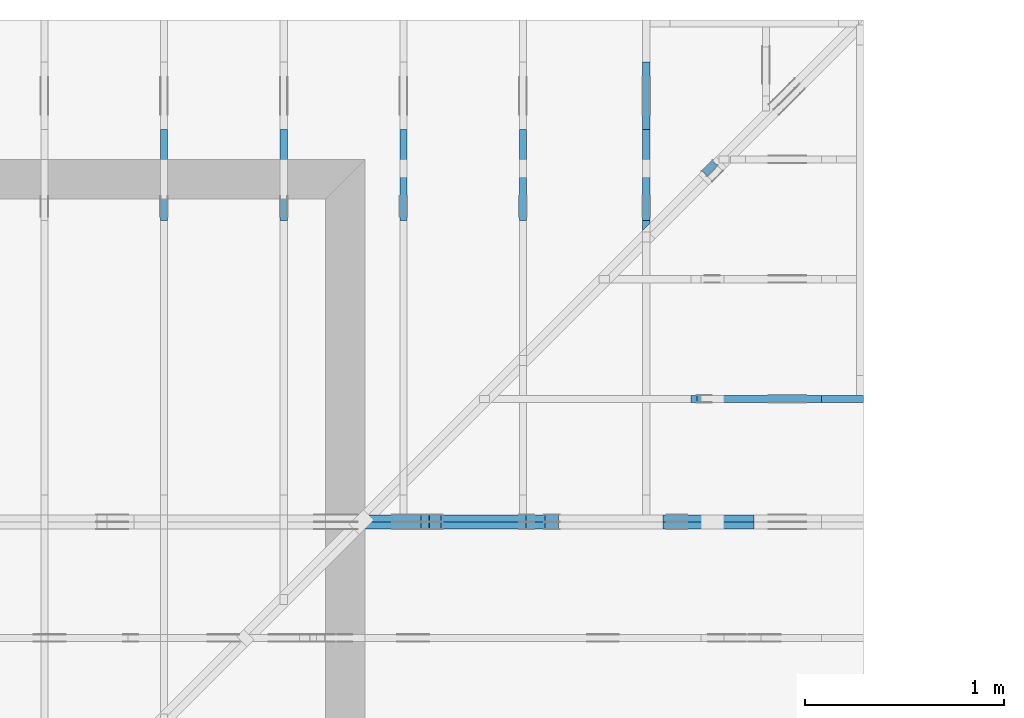
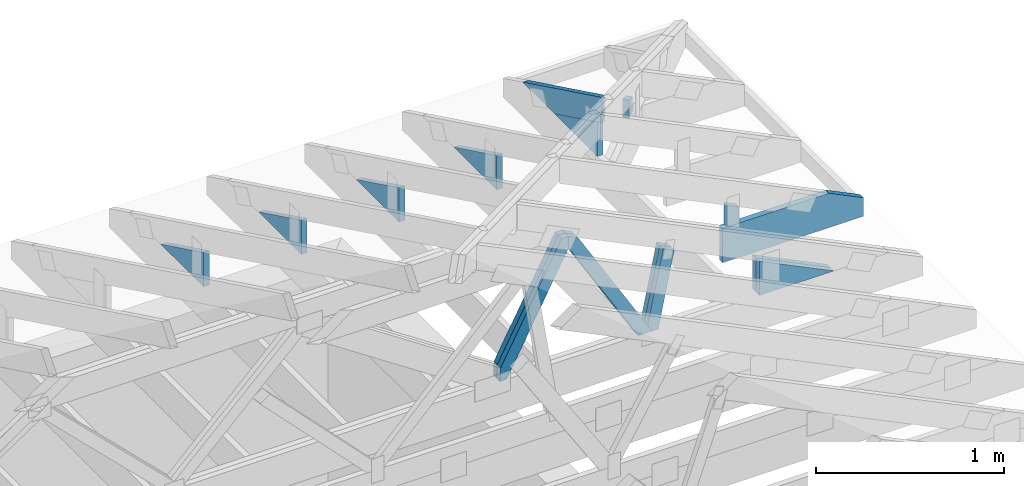
# One storey, part 52 of 159: 17 members, 8 elements without a shape of their own.
"""IFC2X3 building model written with IfcOpenShell, lengths in millimetres."""

from ifc_helpers import new_model, si_unit, frame, origin, origin_with_axes, origin_2d, place, context, project, spatial, faceted_brep, element, aggregate, save


model = new_model("IFC2X3")

# Units and contexts
model_context = context("Model", 3, precision=1e-05, world=origin())
plan_context = context("Plan", 2, precision=1e-05, world=origin_2d())
ifc_project = project(units=[si_unit("LENGTHUNIT", "METRE", prefix="MILLI"), si_unit("AREAUNIT", "SQUARE_METRE"), si_unit("VOLUMEUNIT", "CUBIC_METRE"), si_unit("SOLIDANGLEUNIT", "STERADIAN"), si_unit("PLANEANGLEUNIT", "RADIAN"), si_unit("MASSUNIT", "GRAM"), si_unit("TIMEUNIT", "SECOND"), si_unit("THERMODYNAMICTEMPERATUREUNIT", "DEGREE_CELSIUS"), si_unit("LUMINOUSINTENSITYUNIT", "LUMEN")], contexts=[model_context, plan_context])

# Site, building, storey
site_placement = place(None, origin_with_axes())
site = spatial("IfcSite", under=ifc_project, at=site_placement, CompositionType="ELEMENT")
building_placement = place(site_placement, origin_with_axes())
building = spatial("IfcBuilding", under=site, at=building_placement, Name="Plan 1", CompositionType="ELEMENT")
storey_placement = place(building_placement, origin_with_axes())
storey = spatial("IfcBuildingStorey", under=building, at=storey_placement, Name="Etasje 1", CompositionType="ELEMENT", Elevation=0.0)

# Assembly, members
assembly_1_placement = place(storey_placement, frame((19200.01266310149, 11417.999978540158, 0.0), z_axis=(1.2246063538223773e-16, 1.0, 6.123031769111886e-17), x_axis=(-1.0, 1.2246063538223773e-16, 0.0)))
assembly_1 = element("IfcElementAssembly", 1, at=assembly_1_placement, inside=storey, Name="V9 (1)", AssemblyPlace="FACTORY", PredefinedType="TRUSS")
member_1_placement = place(assembly_1_placement, frame((2147.17242569725, 1036.525654705254, -36.0), z_axis=(0.0, 0.0, 1.0), x_axis=(-0.5106442206411709, -0.8597921143658921, 0.0)))
member_1 = element("IfcMember", 2, at=member_1_placement, Name="V9-D52", context=model_context, shape_type="Brep", body=[
    faceted_brep([(902.8328949356044, 73.00004492890571, 36.0), (65.0651518296686, 73.00004492890571, 36.0), (0.0, 36.500109060107434, 36.0), (55.580187036672214, 5.475690727507754e-05, 36.0), (946.1887834424253, 5.475690727507754e-05, 36.0), (65.0651518296686, 73.00004492890571, 7.967919834302984e-15), (902.8328949356044, 73.00004492890571, 1.1056148995779919e-13), (946.1887834424253, 5.475690727507754e-05, 1.1587087961190594e-13), (55.580187036672214, 5.475690727507754e-05, 6.806385019174492e-15), (0.0, 36.500109060107434, 0.0), (2.7086670565168447e-05, 36.500022463280175, 3.944304526105059e-31), (2.7086670566944804e-05, 36.500022463280175, 36.0), (65.06518656391151, 73.00002246445024, 36.0), (65.06518656391151, 73.00002246445024, 1.1832913578315177e-30), (55.58023588162587, 2.2464449568104783e-05, 0.0), (55.58023588162587, 2.2464449571657497e-05, 36.0), (2.7086670566944804e-05, 36.500022463280175, 36.0), (2.7086670566944804e-05, 36.500022463280175, 3.944304526105059e-31), (946.18877010043, 2.2464450950891487e-05, 2.6056228585185683e-29), (946.18877010043, 2.246445095309578e-05, 36.0), (55.58023588162587, 2.2464449534653947e-05, 36.0), (55.58023588162587, 2.2464449532449656e-05, 1.5305735783864743e-30), (902.8329082776017, 73.00002246445126, 2.015989991758447e-29), (902.8329082776017, 73.00002246445126, 36.0), (946.1887701004302, 2.2464451490122883e-05, 36.0), (946.1887701004302, 2.2464451490122883e-05, 2.0421531320973567e-29), (65.06518656391152, 73.00002246445024, -7.888609052210118e-31), (65.06518656391152, 73.00002246445024, 36.0), (902.8329082776015, 73.0000224644511, 36.0), (902.8329082776015, 73.00002246445112, -1.5777218104420236e-30)], [[[0, 1, 2, 3, 4]], [[5, 6, 7, 8, 9]], [[10, 11, 12, 13]], [[14, 15, 16, 17]], [[18, 19, 20, 21]], [[22, 23, 24, 25]], [[26, 27, 28, 29]]]),
])
member_2_placement = place(assembly_1_placement, frame((2147.17242569725, 1036.525654705254, -72.0), z_axis=(0.0, 0.0, 1.0), x_axis=(-0.5106442206411709, -0.8597921143658921, 0.0)))
member_2 = element("IfcMember", 3, at=member_2_placement, Name="V9-D52", context=model_context, shape_type="Brep", body=[
    faceted_brep([(902.8328949356044, 73.00004492890571, 36.0), (65.0651518296686, 73.00004492890571, 36.0), (0.0, 36.500109060107434, 36.0), (55.580187036672214, 5.475690727507754e-05, 36.0), (946.1887834424253, 5.475690727507754e-05, 36.0), (65.0651518296686, 73.00004492890571, 7.967919834302984e-15), (902.8328949356044, 73.00004492890571, 1.1056148995779919e-13), (946.1887834424253, 5.475690727507754e-05, 1.1587087961190594e-13), (55.580187036672214, 5.475690727507754e-05, 6.806385019174492e-15), (0.0, 36.500109060107434, 0.0), (2.7086670565168447e-05, 36.500022463280175, 3.944304526105059e-31), (2.7086670566944804e-05, 36.500022463280175, 36.0), (65.06518656391151, 73.00002246445024, 36.0), (65.06518656391151, 73.00002246445024, 1.1832913578315177e-30), (55.58023588162587, 2.2464449568104783e-05, 0.0), (55.58023588162587, 2.2464449571657497e-05, 36.0), (2.7086670566944804e-05, 36.500022463280175, 36.0), (2.7086670566944804e-05, 36.500022463280175, 3.944304526105059e-31), (946.18877010043, 2.2464450950891487e-05, 2.6056228585185683e-29), (946.18877010043, 2.246445095309578e-05, 36.0), (55.58023588162587, 2.2464449534653947e-05, 36.0), (55.58023588162587, 2.2464449532449656e-05, 1.5305735783864743e-30), (902.8329082776017, 73.00002246445126, 2.015989991758447e-29), (902.8329082776017, 73.00002246445126, 36.0), (946.1887701004302, 2.2464451490122883e-05, 36.0), (946.1887701004302, 2.2464451490122883e-05, 2.0421531320973567e-29), (65.06518656391152, 73.00002246445024, -7.888609052210118e-31), (65.06518656391152, 73.00002246445024, 36.0), (902.8329082776015, 73.0000224644511, 36.0), (902.8329082776015, 73.00002246445112, -1.5777218104420236e-30)], [[[0, 1, 2, 3, 4]], [[5, 6, 7, 8, 9]], [[10, 11, 12, 13]], [[14, 15, 16, 17]], [[18, 19, 20, 21]], [[22, 23, 24, 25]], [[26, 27, 28, 29]]]),
])
member_3_placement = place(assembly_1_placement, frame((2146.290166525298, 1000.8211263302463, -36.0), z_axis=(0.0, 0.0, 1.0), x_axis=(0.4675598504153547, -0.8839614167369361, 0.0)))
member_3 = element("IfcMember", 4, at=member_3_placement, Name="V9-D55", context=model_context, shape_type="Brep", body=[
    faceted_brep([(821.1597178334184, 73.00008756388706, 36.0), (19.30619502132629, 73.00008756388706, 36.0), (5.9781849017781497e-05, 36.50016454658953, 36.0), (65.06517371963639, 0.00014569213362847222, 36.0), (879.9265574299643, 0.00014569213362847222, 36.0), (899.2328068197955, 36.50016454658953, 36.0), (19.30619502132629, 73.00008756388706, 2.364248909125012e-15), (821.1597178334184, 73.00008756388706, 1.0055974079617946e-13), (899.2328068197955, 36.50016454658953, 1.101206208797052e-13), (879.9265574299643, 0.00014569213362847222, 1.0775636531257853e-13), (65.06517371963639, 0.00014569213362847222, 7.967922514962348e-15), (5.9781849017781497e-05, 36.50016454658953, 7.320923215042526e-21), (-3.552713678800501e-15, 36.500096290976686, 2.950072410108183e-31), (-1.7763568394002505e-15, 36.500096290976686, 36.0), (19.306198457980017, 73.0000962921745, 36.0), (19.306198457980017, 73.0000962921745, 1.1538444380923034e-30), (65.06515947856828, 9.629217493056785e-05, -3.944304526105059e-31), (65.06515947856828, 9.629217493412057e-05, 36.0), (0.0, 36.50009629097667, 36.0), (-1.7763568394002505e-15, 36.50009629097667, 0.0), (879.9266083624536, 9.629217547784367e-05, 2.2178777526116974e-29), (879.9266083624536, 9.629217548004797e-05, 36.0), (65.06515947856826, 9.629217490598829e-05, 36.0), (65.06515947856826, 9.6292174903784e-05, 1.6399842667418017e-30), (899.2328068198412, 36.5000962921564, -1.8932661725304283e-29), (899.2328068198412, 36.5000962921564, 36.0), (879.9266083624534, 9.629217595374939e-05, 36.0), (879.9266083624534, 9.629217595374939e-05, -1.8932661725304283e-29), (821.1597306226265, 73.00009629217493, -3.1554436208840472e-30), (821.1597306226265, 73.00009629217493, 36.0), (899.2328068198415, 36.500096292156286, 36.0), (899.2328068198415, 36.500096292156286, 0.0), (19.30619845798003, 73.00009629217448, -7.888609052210118e-31), (19.30619845798003, 73.00009629217448, 36.0), (821.1597306226267, 73.00009629217514, 36.0), (821.1597306226267, 73.00009629217514, 1.262177448353619e-29)], [[[0, 1, 2, 3, 4, 5]], [[6, 7, 8, 9, 10, 11]], [[12, 13, 14, 15]], [[16, 17, 18, 19]], [[20, 21, 22, 23]], [[24, 25, 26, 27]], [[28, 29, 30, 31]], [[32, 33, 34, 35]]]),
])
member_4_placement = place(assembly_1_placement, frame((2146.290166525298, 1000.8211263302463, -72.0), z_axis=(0.0, 0.0, 1.0), x_axis=(0.4675598504153547, -0.8839614167369361, 0.0)))
member_4 = element("IfcMember", 5, at=member_4_placement, Name="V9-D55", context=model_context, shape_type="Brep", body=[
    faceted_brep([(821.1597178334184, 73.00008756388706, 36.0), (19.30619502132629, 73.00008756388706, 36.0), (5.9781849017781497e-05, 36.50016454658953, 36.0), (65.06517371963639, 0.00014569213362847222, 36.0), (879.9265574299643, 0.00014569213362847222, 36.0), (899.2328068197955, 36.50016454658953, 36.0), (19.30619502132629, 73.00008756388706, 2.364248909125012e-15), (821.1597178334184, 73.00008756388706, 1.0055974079617946e-13), (899.2328068197955, 36.50016454658953, 1.101206208797052e-13), (879.9265574299643, 0.00014569213362847222, 1.0775636531257853e-13), (65.06517371963639, 0.00014569213362847222, 7.967922514962348e-15), (5.9781849017781497e-05, 36.50016454658953, 7.320923215042526e-21), (-3.552713678800501e-15, 36.500096290976686, 2.950072410108183e-31), (-1.7763568394002505e-15, 36.500096290976686, 36.0), (19.306198457980017, 73.0000962921745, 36.0), (19.306198457980017, 73.0000962921745, 1.1538444380923034e-30), (65.06515947856828, 9.629217493056785e-05, -3.944304526105059e-31), (65.06515947856828, 9.629217493412057e-05, 36.0), (0.0, 36.50009629097667, 36.0), (-1.7763568394002505e-15, 36.50009629097667, 0.0), (879.9266083624536, 9.629217547784367e-05, 2.2178777526116974e-29), (879.9266083624536, 9.629217548004797e-05, 36.0), (65.06515947856826, 9.629217490598829e-05, 36.0), (65.06515947856826, 9.6292174903784e-05, 1.6399842667418017e-30), (899.2328068198412, 36.5000962921564, -1.8932661725304283e-29), (899.2328068198412, 36.5000962921564, 36.0), (879.9266083624534, 9.629217595374939e-05, 36.0), (879.9266083624534, 9.629217595374939e-05, -1.8932661725304283e-29), (821.1597306226265, 73.00009629217493, -3.1554436208840472e-30), (821.1597306226265, 73.00009629217493, 36.0), (899.2328068198415, 36.500096292156286, 36.0), (899.2328068198415, 36.500096292156286, 0.0), (19.30619845798003, 73.00009629217448, -7.888609052210118e-31), (19.30619845798003, 73.00009629217448, 36.0), (821.1597306226267, 73.00009629217514, 36.0), (821.1597306226267, 73.00009629217514, 1.262177448353619e-29)], [[[0, 1, 2, 3, 4, 5]], [[6, 7, 8, 9, 10, 11]], [[12, 13, 14, 15]], [[16, 17, 18, 19]], [[20, 21, 22, 23]], [[24, 25, 26, 27]], [[28, 29, 30, 31]], [[32, 33, 34, 35]]]),
])
member_5_placement = place(assembly_1_placement, frame((1006.0125131960103, 446.0, -36.0), z_axis=(0.0, 0.0, 1.0), x_axis=(-1.0, 1.2246063538223773e-16, 0.0)))
member_5 = element("IfcMember", 6, at=member_5_placement, Name="V9-KI3", context=model_context, shape_type="Brep", body=[
    faceted_brep([(9.889790817396715e-07, 223.0, 36.0), (9.889790817396715e-07, 0.0, 36.0), (457.2177744264791, 223.00000000000006, 36.0), (9.889790817396715e-07, 223.0, 0.0), (457.2177744264791, 223.00000000000006, 0.0), (9.889790817396715e-07, 0.0, 0.0), (0.0, 0.0, 0.0), (2.204291436880279e-15, -2.6993892992798474e-31, 36.0), (2.951301312711929e-14, 223.0, 36.0), (2.7308721690239013e-14, 223.0, -1.6721217048316832e-30), (457.2177566736083, 222.99999999999991, 1.1044052673094165e-29), (457.2177566736083, 222.99999999999991, 36.0), (-9.662977650401175e-16, 1.9812040197774178e-15, 36.0), (0.0, 0.0, 0.0), (0.0, 223.0, 0.0), (0.0, 223.0, 36.0), (457.2177566736082, 223.00000000000009, 36.0), (457.2177566736082, 223.00000000000009, 1.5777218104420236e-30)], [[[0, 1, 2]], [[3, 4, 5]], [[6, 7, 8, 9]], [[10, 11, 12, 13]], [[14, 15, 16, 17]]]),
])
member_6_placement = place(assembly_1_placement, frame((1006.0125131960103, 446.0, -72.0), z_axis=(0.0, 0.0, 1.0), x_axis=(-1.0, 1.2246063538223773e-16, 0.0)))
member_6 = element("IfcMember", 7, at=member_6_placement, Name="V9-KI3", context=model_context, shape_type="Brep", body=[
    faceted_brep([(9.889790817396715e-07, 223.0, 36.0), (9.889790817396715e-07, 0.0, 36.0), (457.2177744264791, 223.00000000000006, 36.0), (9.889790817396715e-07, 223.0, 0.0), (457.2177744264791, 223.00000000000006, 0.0), (9.889790817396715e-07, 0.0, 0.0), (0.0, 0.0, 0.0), (2.204291436880279e-15, -2.6993892992798474e-31, 36.0), (2.951301312711929e-14, 223.0, 36.0), (2.7308721690239013e-14, 223.0, -1.6721217048316832e-30), (457.2177566736083, 222.99999999999991, 1.1044052673094165e-29), (457.2177566736083, 222.99999999999991, 36.0), (-9.662977650401175e-16, 1.9812040197774178e-15, 36.0), (0.0, 0.0, 0.0), (0.0, 223.0, 0.0), (0.0, 223.0, 36.0), (457.2177566736082, 223.00000000000009, 36.0), (457.2177566736082, 223.00000000000009, 1.5777218104420236e-30)], [[[0, 1, 2]], [[3, 4, 5]], [[6, 7, 8, 9]], [[10, 11, 12, 13]], [[14, 15, 16, 17]]]),
])
member_7_placement = place(assembly_1_placement, frame((1699.7593655308665, 230.34806849630263, -36.00000000000001), z_axis=(0.0, 0.0, 1.0), x_axis=(-0.20131671299733636, 0.979526202338635, 0.0)))
member_7 = element("IfcMember", 8, at=member_7_placement, Name="V9-D70", context=model_context, shape_type="Brep", body=[
    faceted_brep([(495.34013399546416, 73.0000140499244, 36.0), (7.501657747279012, 73.0000140499244, 36.0), (5.259957163161744e-06, 36.500067675283844, 36.0), (40.0838364325748, 0.0, 36.0), (514.0643720772766, 0.0, 36.0), (7.501657747279012, 73.0000140499244, 9.18657774151874e-16), (495.34013399546416, 73.0000140499244, 6.065966753940732e-14), (514.0643720772766, 0.0, 6.295264963195436e-14), (40.0838364325748, 0.0, 4.908692078090799e-15), (5.259957163161744e-06, 36.500067675283844, 6.441376962841398e-22), (-1.1546319456101628e-14, 36.500042082446726, 8.439467349881614e-31), (-9.769962616701378e-15, 36.500042082446726, 36.0), (7.501647231956754, 73.00004208244674, 36.0), (7.501647231956753, 73.00004208244674, 1.8874354750202937e-30), (40.0838491851033, 4.208244831005459e-05, 5.9164567891575885e-31), (40.0838491851033, 4.208244831005459e-05, 36.0), (0.0, 36.500042082446726, 36.0), (0.0, 36.500042082446726, 0.0), (514.064392807977, 4.20824482419597e-05, -9.317623492188373e-30), (514.064392807977, 4.208244824416399e-05, 36.0), (40.083849185103304, 4.208244833122993e-05, 36.0), (40.083849185103304, 4.208244832902564e-05, -7.26536006661318e-31), (495.340146190407, 73.00004208244789, 6.472228055559362e-30), (495.340146190407, 73.00004208244789, 36.0), (514.0643928079771, 4.208244808978634e-05, 36.0), (514.0643928079771, 4.208244808978634e-05, 6.704458548795174e-30), (7.501647231956781, 73.00004208244673, 0.0), (7.501647231956781, 73.00004208244673, 36.0), (495.3401461904069, 73.00004208244789, 36.0), (495.3401461904069, 73.00004208244789, 1.5777218104420236e-30)], [[[0, 1, 2, 3, 4]], [[5, 6, 7, 8, 9]], [[10, 11, 12, 13]], [[14, 15, 16, 17]], [[18, 19, 20, 21]], [[22, 23, 24, 25]], [[26, 27, 28, 29]]]),
])
member_8_placement = place(assembly_1_placement, frame((1699.7593655308665, 230.34806849630263, -72.00000000000001), z_axis=(0.0, 0.0, 1.0), x_axis=(-0.20131671299733636, 0.979526202338635, 0.0)))
member_8 = element("IfcMember", 9, at=member_8_placement, Name="V9-D70", context=model_context, shape_type="Brep", body=[
    faceted_brep([(495.34013399546416, 73.0000140499244, 36.0), (7.501657747279012, 73.0000140499244, 36.0), (5.259957163161744e-06, 36.500067675283844, 36.0), (40.0838364325748, 0.0, 36.0), (514.0643720772766, 0.0, 36.0), (7.501657747279012, 73.0000140499244, 9.18657774151874e-16), (495.34013399546416, 73.0000140499244, 6.065966753940732e-14), (514.0643720772766, 0.0, 6.295264963195436e-14), (40.0838364325748, 0.0, 4.908692078090799e-15), (5.259957163161744e-06, 36.500067675283844, 6.441376962841398e-22), (-1.1546319456101628e-14, 36.500042082446726, 8.439467349881614e-31), (-9.769962616701378e-15, 36.500042082446726, 36.0), (7.501647231956754, 73.00004208244674, 36.0), (7.501647231956753, 73.00004208244674, 1.8874354750202937e-30), (40.0838491851033, 4.208244831005459e-05, 5.9164567891575885e-31), (40.0838491851033, 4.208244831005459e-05, 36.0), (0.0, 36.500042082446726, 36.0), (0.0, 36.500042082446726, 0.0), (514.064392807977, 4.20824482419597e-05, -9.317623492188373e-30), (514.064392807977, 4.208244824416399e-05, 36.0), (40.083849185103304, 4.208244833122993e-05, 36.0), (40.083849185103304, 4.208244832902564e-05, -7.26536006661318e-31), (495.340146190407, 73.00004208244789, 6.472228055559362e-30), (495.340146190407, 73.00004208244789, 36.0), (514.0643928079771, 4.208244808978634e-05, 36.0), (514.0643928079771, 4.208244808978634e-05, 6.704458548795174e-30), (7.501647231956781, 73.00004208244673, 0.0), (7.501647231956781, 73.00004208244673, 36.0), (495.3401461904069, 73.00004208244789, 36.0), (495.3401461904069, 73.00004208244789, 1.5777218104420236e-30)], [[[0, 1, 2, 3, 4]], [[5, 6, 7, 8, 9]], [[10, 11, 12, 13]], [[14, 15, 16, 17]], [[18, 19, 20, 21]], [[22, 23, 24, 25]], [[26, 27, 28, 29]]]),
])
aggregate(assembly_1, [member_1, member_2, member_3, member_4, member_5, member_6, member_7, member_8])

# Assembly, member
assembly_2_placement = place(storey_placement, frame((19174.556818978774, 13925.455822662876, 2.204291436880279e-15), z_axis=(-0.7071067811865465, 0.7071067811865486, 6.123031769111886e-17), x_axis=(-0.7071067811865486, -0.7071067811865465, 0.0)))
assembly_2 = element("IfcElementAssembly", 10, at=assembly_2_placement, inside=storey, Name="GR3 (58)", AssemblyPlace="FACTORY", PredefinedType="TRUSS")
member_9_placement = place(assembly_2_placement, frame((1107.3371583767168, 223.0, -36.0), z_axis=(0.0, 0.0, 1.0), x_axis=(6.123031769111886e-17, 1.0, 0.0)))
member_9 = element("IfcMember", 11, at=member_9_placement, Name="GR3-D77", context=model_context, shape_type="Brep", body=[
    faceted_brep([(90.95892333984375, 73.00000017359184, 36.0), (0.0, 73.00000017359184, 36.0), (0.0, 1.7359184312226716e-07, 36.0), (116.13507080078125, 1.7359184312226716e-07, 36.0), (0.0, 73.00000017359184, 0.0), (90.95892333984375, 73.00000017359184, 1.1138887545881518e-14), (116.13507080078125, 1.7359184312226716e-07, 1.4221974560424836e-14), (0.0, 1.7359184312226716e-07, 0.0), (1.5830892152735032e-10, 0.0, 0.0), (1.583111258187872e-10, -8.577881281512834e-28, 36.0), (1.867186822366619e-10, 73.0, 36.0), (1.8671647794522503e-10, 73.0, -8.736768442928876e-31), (116.1350835837651, -2.133296418875574e-14, 1.3062241745707756e-30), (116.1350835837651, -1.912867275187546e-14, 36.0), (1.5830892152735032e-10, 2.2042914368511993e-15, 36.0), (1.5830892152735032e-10, -2.90799166753742e-26, 1.7805725364644272e-42), (90.95891506678528, 73.0, 6.675876479602264e-31), (90.95891506678528, 73.0, 36.0), (116.13508358376511, 0.0, 36.0), (116.13508358376511, 0.0, 9.055383698773292e-31), (1.8670220924832392e-10, 73.0, 0.0), (1.8670220924832392e-10, 73.0, 36.0), (90.95891506678527, 72.99999999999999, 36.0), (90.95891506678527, 73.0, 0.0)], [[[0, 1, 2, 3]], [[4, 5, 6, 7]], [[8, 9, 10, 11]], [[12, 13, 14, 15]], [[16, 17, 18, 19]], [[20, 21, 22, 23]]]),
])
aggregate(assembly_2, [member_9])

assembly_3_placement = place(storey_placement, frame((16275.022261404762, 13899.999978540158, 1.1021457184401395e-15), z_axis=(-1.0, 1.836909530733566e-16, 6.123031769111886e-17), x_axis=(-1.836909530733566e-16, -1.0, 0.0)))
assembly_3 = element("IfcElementAssembly", 12, at=assembly_3_placement, inside=storey, Name="S39 (62)", AssemblyPlace="FACTORY", PredefinedType="TRUSS")
member_10_placement = place(assembly_3_placement, frame((1006.0125131974528, 446.0, -36.0), z_axis=(0.0, 0.0, 1.0), x_axis=(-1.0, 4.091286229072899e-13, 0.0)))
member_10 = element("IfcMember", 13, at=member_10_placement, Name="S39-KI3", context=model_context, shape_type="Brep", body=[
    faceted_brep([(9.903303634928307e-07, 223.00000000000003, 36.0), (9.904215403366834e-07, 0.0, 36.0), (457.21777442783036, 223.00000000018707, 36.0), (9.903303634928307e-07, 223.00000000000003, 0.0), (457.21777442783036, 223.00000000018707, 0.0), (9.904215403366834e-07, 0.0, 0.0), (9.117684385273604e-11, -5.877471754111438e-39, 7.174648137343064e-43), (9.117904814417292e-11, 9.012988421914265e-28, 36.0), (-2.0173207722610032e-15, 223.00000000000003, 36.0), (-4.221612209141282e-15, 223.00000000000003, 2.58490656734279e-31), (457.21775667309697, 223.00000000018665, 2.868525454971601e-29), (457.21775667309697, 223.00000000018665, 36.0), (9.117587755497104e-11, 1.9812040197098783e-15, 36.0), (9.117684385273608e-11, -6.462348535570529e-26, 4.304788882405838e-42), (0.0, 223.00000000000003, 0.0), (0.0, 223.00000000000003, 36.0), (457.2177566730968, 223.0000000001871, 36.0), (457.2177566730968, 223.0000000001871, 1.5777218104420236e-30)], [[[0, 1, 2]], [[3, 4, 5]], [[6, 7, 8, 9]], [[10, 11, 12, 13]], [[14, 15, 16, 17]]]),
])
aggregate(assembly_3, [member_10])

assembly_4_placement = place(storey_placement, frame((15675.022261404756, 13899.999978540158, 1.1021457184401395e-15), z_axis=(-1.0, 1.836909530733566e-16, 6.123031769111886e-17), x_axis=(-1.836909530733566e-16, -1.0, 0.0)))
assembly_4 = element("IfcElementAssembly", 14, at=assembly_4_placement, inside=storey, Name="S38 (64)", AssemblyPlace="FACTORY", PredefinedType="TRUSS")
member_11_placement = place(assembly_4_placement, frame((1006.0125131970788, 446.0, -36.0), z_axis=(0.0, 0.0, 1.0), x_axis=(-1.0, 4.091286229072899e-13, 0.0)))
member_11 = element("IfcMember", 15, at=member_11_placement, Name="S38-KI3", context=model_context, shape_type="Brep", body=[
    faceted_brep([(9.899563337967265e-07, 223.00000000000003, 36.0), (9.900475106405793e-07, 0.0, 36.0), (457.21777442745633, 223.00000000018707, 36.0), (9.899563337967265e-07, 223.00000000000003, 0.0), (457.21777442745633, 223.00000000018707, 0.0), (9.900475106405793e-07, 0.0, 0.0), (9.117684385273604e-11, -5.877471754111438e-39, 7.174648137343064e-43), (9.117904814417292e-11, 9.012988421914265e-28, 36.0), (-2.0173207722610032e-15, 223.00000000000003, 36.0), (-4.221612209141282e-15, 223.00000000000003, 2.58490656734279e-31), (457.2177566727228, 223.0000000001871, 1.8639837738198495e-30), (457.2177566727228, 223.0000000001871, 36.0), (9.117587755497102e-11, 1.9812040197680394e-15, 36.0), (9.117684385273606e-11, -6.462348535570529e-27, 7.174648137343064e-43), (0.0, 223.00000000000003, 0.0), (0.0, 223.00000000000003, 36.0), (457.21775667272277, 223.0000000001871, 36.0), (457.21775667272277, 223.0000000001871, 1.5777218104420236e-30)], [[[0, 1, 2]], [[3, 4, 5]], [[6, 7, 8, 9]], [[10, 11, 12, 13]], [[14, 15, 16, 17]]]),
])
aggregate(assembly_4, [member_11])

assembly_5_placement = place(storey_placement, frame((16875.02226140476, 13899.999978540158, 1.1021457184401395e-15), z_axis=(-1.0, 1.836909530733566e-16, 6.123031769111886e-17), x_axis=(-1.836909530733566e-16, -1.0, 0.0)))
assembly_5 = element("IfcElementAssembly", 16, at=assembly_5_placement, inside=storey, Name="S40 (65)", AssemblyPlace="FACTORY", PredefinedType="TRUSS")
member_12_placement = place(assembly_5_placement, frame((548.7947387695312, 223.0, -36.0), z_axis=(0.0, 0.0, 1.0), x_axis=(1.0, -4.096951727525222e-13, 0.0)))
member_12 = element("IfcMember", 17, at=member_12_placement, Name="S40-KI3", context=model_context, shape_type="Brep", body=[
    faceted_brep([(457.2177734374087, 223.00000000018733, 36.0), (0.0, 0.0, 36.0), (457.2177734375, 1.8732748685579281e-10, 36.0), (457.2177734374087, 223.00000000018733, 0.0), (457.2177734375, 1.8732748685579281e-10, 0.0), (0.0, 0.0, 0.0), (1.7756377925027292e-05, 8.00363257867111e-10, 5.395708089765912e-31), (1.775637792599359e-05, 8.003612766629766e-10, 36.0), (457.21777442775374, 223.0000000007986, 36.0), (457.21777442775374, 223.0000000007986, 7.21684468760785e-30), (457.2177744274625, 2.0498131872579603e-09, 9.763102442263215e-30), (457.2177744274625, 2.049815391549397e-09, 36.0), (1.7756377928890288e-05, 8.003575418454215e-10, 36.0), (1.7756377928890288e-05, 8.003553375539846e-10, 3.791600650437963e-37), (457.2177744274625, 223.0000000007985, -1.7844033676099287e-26), (457.2177744274625, 223.0000000007985, 36.0), (457.2177744274625, 2.04997263608675e-09, 36.0), (457.2177744274625, 2.04997263608675e-09, 0.0)], [[[0, 1, 2]], [[3, 4, 5]], [[6, 7, 8, 9]], [[10, 11, 12, 13]], [[14, 15, 16, 17]]]),
])
aggregate(assembly_5, [member_12])

assembly_6_placement = place(storey_placement, frame((17475.02226140476, 13899.999978540158, 1.1021457184401395e-15), z_axis=(-1.0, 1.836909530733566e-16, 6.123031769111886e-17), x_axis=(-1.836909530733566e-16, -1.0, 0.0)))
assembly_6 = element("IfcElementAssembly", 18, at=assembly_6_placement, inside=storey, Name="S41 (67)", AssemblyPlace="FACTORY", PredefinedType="TRUSS")
member_13_placement = place(assembly_6_placement, frame((548.7947387695312, 223.0, -36.0), z_axis=(0.0, 0.0, 1.0), x_axis=(1.0, -4.096951727525222e-13, 0.0)))
member_13 = element("IfcMember", 19, at=member_13_placement, Name="S41-KI3", context=model_context, shape_type="Brep", body=[
    faceted_brep([(457.2177734374087, 223.00000000018733, 36.0), (0.0, 0.0, 36.0), (457.2177734375, 1.8732748685579281e-10, 36.0), (457.2177734374087, 223.00000000018733, 0.0), (457.2177734375, 1.8732748685579281e-10, 0.0), (0.0, 0.0, 0.0), (1.775634883003575e-05, 7.857932201909608e-10, -6.950206269575802e-31), (1.775634883100205e-05, 7.857912389868264e-10, 36.0), (457.21777442757923, 223.00000000079123, 36.0), (457.21777442757923, 223.00000000079123, 5.330974086063869e-31), (457.217774428235, 2.0498805460392683e-09, 5.638702863489126e-30), (457.217774428235, 2.049882750330705e-09, 36.0), (1.775634882505983e-05, 7.858056266196706e-10, 36.0), (1.775634882505983e-05, 7.858034223282337e-10, 2.1898174058873004e-37), (457.217774428235, 223.00000000079123, 4.01530200757495e-26), (457.217774428235, 223.00000000079123, 36.0), (457.217774428235, 2.04997263608675e-09, 36.0), (457.217774428235, 2.04997263608675e-09, 0.0)], [[[0, 1, 2]], [[3, 4, 5]], [[6, 7, 8, 9]], [[10, 11, 12, 13]], [[14, 15, 16, 17]]]),
])
aggregate(assembly_6, [member_13])

# Assembly, members
assembly_7_placement = place(storey_placement, frame((19200.01266310149, 12017.999978540158, 1.1021457184401395e-15), z_axis=(1.2246063538223773e-16, 1.0, 6.123031769111886e-17), x_axis=(-1.0, 1.2246063538223773e-16, 0.0)))
assembly_7 = element("IfcElementAssembly", 20, at=assembly_7_placement, inside=storey, Name="S45 (74)", AssemblyPlace="FACTORY", PredefinedType="TRUSS")
member_14_placement = place(assembly_7_placement, frame((864.0063476562501, 223.00000000093095, -36.0), z_axis=(0.0, 0.0, 1.0), x_axis=(-1.0, 5.665498452323003e-16, 0.0)))
member_14 = element("IfcMember", 21, at=member_14_placement, Name="S45-U25", context=model_context, shape_type="Brep", body=[
    faceted_brep([(864.00634765625, 223.00000000093144, 36.0), (0.0, 223.00000000093144, 36.0), (1.1368683772161603e-13, 9.309530923928833e-10, 36.0), (652.8250579833986, 9.309530923928833e-10, 36.0), (864.0063154452365, 102.99998474214237, 36.0), (0.0, 223.00000000093144, 0.0), (864.00634765625, 223.00000000093144, 1.0580676630827096e-13), (864.0063154452365, 102.99998474214237, 1.0580676236368978e-13), (652.8250579833986, 9.309530923928833e-10, 7.994537139409317e-14), (1.1368683772161603e-13, 9.309530923928833e-10, 1.392216238198645e-29), (1.613267897937476e-05, 9.309530923928833e-10, 0.0), (1.613267898157905e-05, 9.309530923928833e-10, 36.0), (1.613267890985588e-05, 223.00000000093095, 36.0), (1.6132678907651587e-05, 223.00000000093095, -2.569448590332465e-30), (652.8250519726427, -3.6595019804825703e-13, 2.2407246885623745e-29), (652.8250519726427, -3.6374590661137675e-13, 36.0), (1.613267897937476e-05, 9.309552966752768e-10, 36.0), (1.613267897937476e-05, 9.309530923838399e-10, 5.53722124084608e-37), (864.0063154452367, 102.99998429075606, 3.470987982972452e-29), (864.0063154452367, 102.99998429075606, 36.0), (652.8250519726429, -3.410605131648481e-13, 36.0), (652.8250519726429, -3.410605131648481e-13, 2.208810534618833e-29), (864.0062877973955, 223.00000000093144, -3.665176671839621e-21), (864.0062877973955, 223.00000000093144, 36.0), (864.0062877973955, 102.99998429075652, 36.0), (864.0062877973955, 102.99998429075652, -1.6928860804496394e-21), (1.613267886568792e-05, 223.00000000093095, 0.0), (1.613267886568792e-05, 223.00000000093095, 36.0), (864.00634765625, 223.00000000093166, 36.0), (864.00634765625, 223.00000000093166, 1.5777218104420236e-29)], [[[0, 1, 2, 3, 4]], [[5, 6, 7, 8, 9]], [[10, 11, 12, 13]], [[14, 15, 16, 17]], [[18, 19, 20, 21]], [[22, 23, 24, 25]], [[26, 27, 28, 29]]]),
])
member_15_placement = place(assembly_7_placement, frame((835.5, 223.0, -36.0), z_axis=(0.0, 0.0, 1.0), x_axis=(6.123031769111886e-17, 1.0, 0.0)))
member_15 = element("IfcMember", 22, at=member_15_placement, Name="S45-D72", context=model_context, shape_type="Brep", body=[
    faceted_brep([(104.23101806640625, 73.0, 36.0), (0.0, 73.0, 36.0), (0.0, 0.0, 36.0), (139.83547973632812, 0.0, 36.0), (0.0, 73.0, 0.0), (104.23101806640625, 73.0, 1.2764196698949609e-14), (139.83547973632812, 0.0, 1.712434169749077e-14), (0.0, 0.0, 0.0), (2.495426087989472e-10, 0.0, 0.0), (2.4954481309038407e-10, -2.4064111593483025e-27, 36.0), (3.292384559970031e-10, 73.0, 36.0), (3.292362517055662e-10, 73.0, 1.7911120491342064e-30), (139.83549055618562, -2.5686514533746092e-14, 1.5727934452788151e-30), (139.83549055618562, -2.3482223096865813e-14, 36.0), (2.495426087989472e-10, 2.2042914368344403e-15, 36.0), (2.495426087989472e-10, -4.583871964269039e-26, 2.806719366276063e-42), (104.23101159078601, 73.0, 0.0), (104.23101159078601, 73.0, 36.0), (139.83549055618562, 0.0, 36.0), (139.83549055618562, 0.0, 0.0), (3.2926550375123043e-10, 73.0, 0.0), (3.2926550375123043e-10, 73.0, 36.0), (104.23101159078601, 72.99999999999999, 36.0), (104.23101159078601, 73.0, 0.0)], [[[0, 1, 2, 3]], [[4, 5, 6, 7]], [[8, 9, 10, 11]], [[12, 13, 14, 15]], [[16, 17, 18, 19]], [[20, 21, 22, 23]]]),
])
aggregate(assembly_7, [member_14, member_15])

assembly_8_placement = place(storey_placement, frame((18093.02226140476, 13899.9999785399, 1.1021457184401395e-15), z_axis=(-1.0, -1.4305706115156844e-11, 6.123031769111886e-17), x_axis=(1.4305706115156844e-11, -1.0, 0.0)))
assembly_8 = element("IfcElementAssembly", 23, at=assembly_8_placement, inside=storey, Name="S42 (81)", AssemblyPlace="FACTORY", PredefinedType="TRUSS")
member_16_placement = place(assembly_8_placement, frame((276.0602052505893, 89.9784713153575, -36.00000021804672), z_axis=(0.0, 0.0, 1.0), x_axis=(0.898794046299167, 0.4383711467890774, 0.0)))
member_16 = element("IfcMember", 24, at=member_16_placement, Name="S42-O71", context=model_context, shape_type="Brep", body=[
    faceted_brep([(940.3567513312175, 147.99999481779977, 36.000003247403754), (868.1723273808859, 7.277947133843554e-10, 36.000000218046864), (828.11865743877, 3.2130120075635205e-07, 5.684341886080802e-14), (900.3030813891016, 147.99999513837312, 3.0293571171569056e-06), (0.0, 148.00000000000642, 2.180467220114224e-07), (0.0, 148.00000000000642, 36.00000021804673), (940.3567504882812, 148.00000000000637, 36.00000021804673), (900.3030815124512, 148.00000000000637, 2.180467220114224e-07), (4.108162545435334e-05, 147.99999999985687, 2.1804672201142742e-07), (900.3030806324068, 147.99999999985687, 2.1804683226310968e-07), (828.1186552784029, 0.0, 2.180468234233591e-07), (303.44498737068795, 0.0, 2.1804675917148835e-07), (303.4449909819773, 5.24877918905986e-10, 2.180467220114224e-07), (303.4449909819773, 5.24877918905986e-10, 36.00000021804672), (1.9268845974806936e-05, 148.00000154146517, 36.00000021804672), (1.9268845974806936e-05, 148.00000154146517, 2.180467220114224e-07), (868.1723265008372, 7.131947602001586e-10, 36.00000021804672), (303.44501250547603, 7.132984954986929e-10, 36.00000021804672), (303.44501250547603, 7.132962912072561e-10, 2.180467220114224e-07), (828.1186575250072, 7.1319991340535e-10, 2.180467220114224e-07), (940.3567527348894, 148.00000000072788, 36.00000021804672), (2.5134791826531e-05, 148.00000000072788, 36.00000021804672), (303.4449714238543, 5.249773948889924e-10, 36.00000021804672), (868.1723273808857, 5.249773948889924e-10, 36.00000021804672)], [[[0, 1, 2, 3]], [[4, 5, 6, 7]], [[8, 9, 10, 11]], [[12, 13, 14, 15]], [[16, 17, 18, 19]], [[20, 21, 22, 23]]]),
])
member_17_placement = place(assembly_8_placement, frame((548.7947387695312, 223.0, -36.0), z_axis=(0.0, 0.0, 1.0), x_axis=(1.0, -4.096951727525222e-13, 0.0)))
member_17 = element("IfcMember", 25, at=member_17_placement, Name="S42-KI3", context=model_context, shape_type="Brep", body=[
    faceted_brep([(457.2177734374087, 223.00000000018733, 36.0), (0.0, 0.0, 36.0), (457.2177734375, 1.8732748685579281e-10, 36.0), (457.2177734374087, 223.00000000018733, 0.0), (457.2177734375, 1.8732748685579281e-10, 0.0), (0.0, 0.0, 0.0), (1.7756363365068802e-05, 7.931037913923346e-10, 1.6630289892934696e-30), (1.77563633660351e-05, 7.931018101882002e-10, 36.0), (457.2177744270845, 223.0000000007912, 36.0), (457.2177744270845, 223.0000000007912, -1.4946715551326776e-30), (457.21777442895007, 2.049846866651635e-09, 7.700902467902262e-30), (457.21777442895007, 2.049849070943072e-09, 36.0), (1.775636337697506e-05, 7.93081584232546e-10, 36.0), (1.775636337697506e-05, 7.930793799411091e-10, 2.9906803295700825e-37), (457.21777442895007, 223.00000000079123, 1.1423336996324428e-25), (457.21777442895007, 223.00000000079123, 36.0), (457.21777442895007, 2.04997263608675e-09, 36.0), (457.21777442895007, 2.04997263608675e-09, 0.0)], [[[0, 1, 2]], [[3, 4, 5]], [[6, 7, 8, 9]], [[10, 11, 12, 13]], [[14, 15, 16, 17]]]),
])
aggregate(assembly_8, [member_16, member_17])

save(model, "model.ifc")
